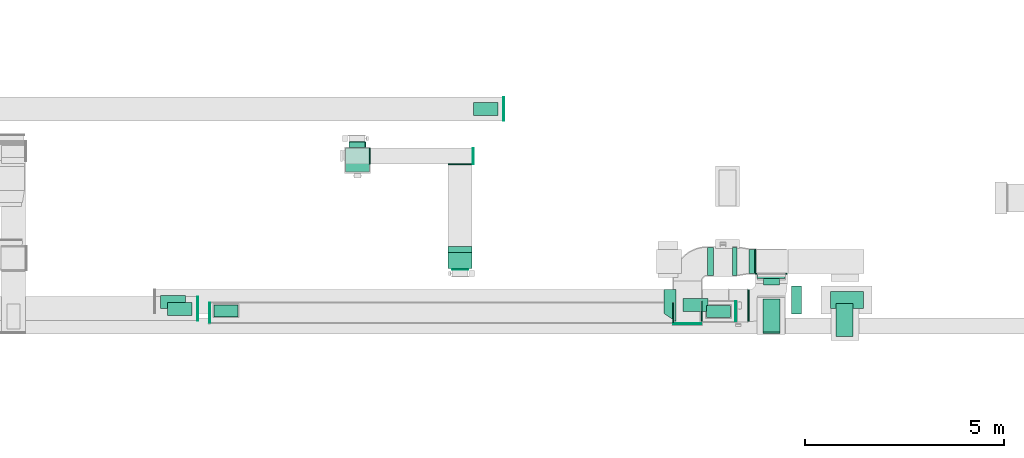
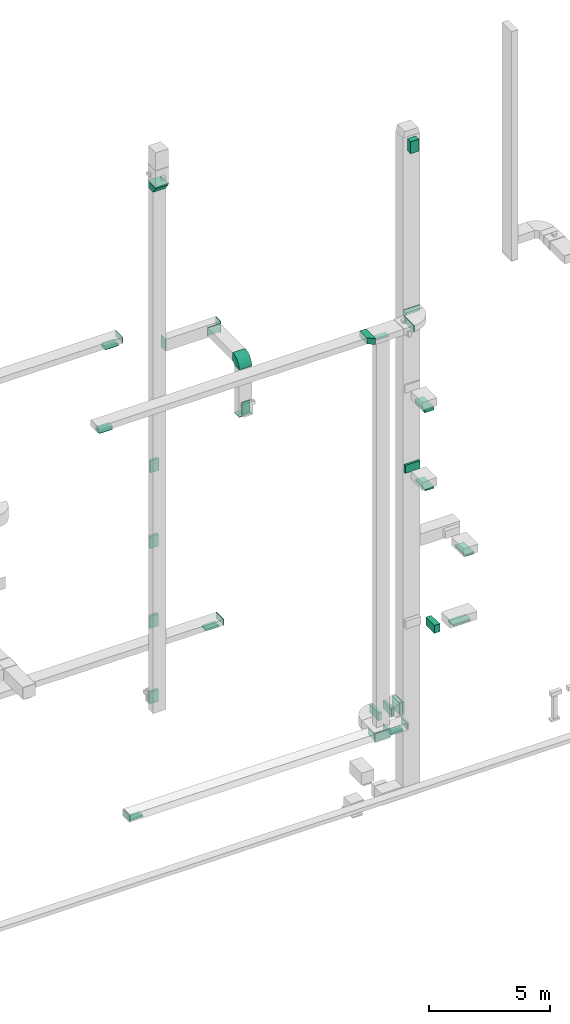
# One storey, part 16 of 29: 25 flow fittings, 22 flow segments, 6 flow terminals.
"""IFC2X3 building model written with IfcOpenShell, lengths in millimetres."""

from ifc_helpers import new_model, entity, si_unit, converted_unit, derived_unit, direction, frame, frame_2d, origin, origin_2d_with_axis, place, context, subcontext, project, spatial, polyline, circle_curve, parameter, trimmed, segment, composite_curve, rectangle, outline, extrude, source, transform, mapped, material, type_object, type_shapes, element, save


model = new_model("IFC2X3")

# Units and contexts
model_context = context("Model", 3, precision=0.01, world=origin(), true_north=direction((6.12303176911189e-17, 1.0)))
body_context = subcontext(model_context, "Body", "Model", "MODEL_VIEW")
ifc_project = project(units=[si_unit("LENGTHUNIT", "METRE", prefix="MILLI"), si_unit("AREAUNIT", "SQUARE_METRE"), si_unit("VOLUMEUNIT", "CUBIC_METRE"), converted_unit("PLANEANGLEUNIT", "DEGREE", entity("IfcRatioMeasure", 0.0174532925199433), si_unit("PLANEANGLEUNIT", "RADIAN"), dimensions=[0, 0, 0, 0, 0, 0, 0]), si_unit("MASSUNIT", "GRAM", prefix="KILO"), derived_unit("MASSDENSITYUNIT", [(si_unit("MASSUNIT", "GRAM", prefix="KILO"), 1), (si_unit("LENGTHUNIT", "METRE"), -3)]), derived_unit("MOMENTOFINERTIAUNIT", [(si_unit("LENGTHUNIT", "METRE"), 4)]), si_unit("TIMEUNIT", "SECOND"), si_unit("FREQUENCYUNIT", "HERTZ"), si_unit("THERMODYNAMICTEMPERATUREUNIT", "DEGREE_CELSIUS"), derived_unit("THERMALTRANSMITTANCEUNIT", [(si_unit("MASSUNIT", "GRAM", prefix="KILO"), 1), (si_unit("THERMODYNAMICTEMPERATUREUNIT", "KELVIN"), -1), (si_unit("TIMEUNIT", "SECOND"), -3)]), derived_unit("VOLUMETRICFLOWRATEUNIT", [(si_unit("LENGTHUNIT", "METRE"), 3), (si_unit("TIMEUNIT", "SECOND"), -1)]), derived_unit("MASSFLOWRATEUNIT", [(si_unit("MASSUNIT", "GRAM", prefix="KILO"), 1), (si_unit("TIMEUNIT", "SECOND"), -1)]), derived_unit("ROTATIONALFREQUENCYUNIT", [(si_unit("TIMEUNIT", "SECOND"), -1)]), si_unit("ELECTRICCURRENTUNIT", "AMPERE"), si_unit("ELECTRICVOLTAGEUNIT", "VOLT"), si_unit("POWERUNIT", "WATT"), si_unit("FORCEUNIT", "NEWTON", prefix="KILO"), si_unit("ILLUMINANCEUNIT", "LUX"), si_unit("LUMINOUSFLUXUNIT", "LUMEN"), si_unit("LUMINOUSINTENSITYUNIT", "CANDELA"), derived_unit("USERDEFINED", [(si_unit("MASSUNIT", "GRAM", prefix="KILO"), -1), (si_unit("LENGTHUNIT", "METRE"), -2), (si_unit("TIMEUNIT", "SECOND"), 3), (si_unit("LUMINOUSFLUXUNIT", "LUMEN"), 1)]), derived_unit("LINEARVELOCITYUNIT", [(si_unit("LENGTHUNIT", "METRE"), 1), (si_unit("TIMEUNIT", "SECOND"), -1)]), si_unit("PRESSUREUNIT", "PASCAL"), derived_unit("USERDEFINED", [(si_unit("LENGTHUNIT", "METRE"), -2), (si_unit("MASSUNIT", "GRAM", prefix="KILO"), 1), (si_unit("TIMEUNIT", "SECOND"), -2)]), derived_unit("LINEARFORCEUNIT", [(si_unit("MASSUNIT", "GRAM", prefix="KILO"), 1), (si_unit("LENGTHUNIT", "METRE"), 1), (si_unit("TIMEUNIT", "SECOND"), -2), (si_unit("LENGTHUNIT", "METRE"), -1)]), derived_unit("PLANARFORCEUNIT", [(si_unit("MASSUNIT", "GRAM", prefix="KILO"), 1), (si_unit("LENGTHUNIT", "METRE"), 1), (si_unit("TIMEUNIT", "SECOND"), -2), (si_unit("LENGTHUNIT", "METRE"), -2)])], contexts=[model_context])

# Site, building, storey
site_placement = place(None, frame((0.0, -0.00077364408347762, 0.0)))
site = spatial("IfcSite", under=ifc_project, at=site_placement, CompositionType="ELEMENT")
building_placement = place(site_placement, origin())
building = spatial("IfcBuilding", under=site, at=building_placement, CompositionType="ELEMENT")
storey_placement = place(building_placement, origin())
storey = spatial("IfcBuildingStorey", under=building, at=storey_placement, CompositionType="ELEMENT", Elevation=0.0)

# Flow segments
duct_segment_type_1 = type_object("IfcDuctSegmentType", PredefinedType="NOTDEFINED")
flow_segment_1_placement = place(storey_placement, frame((62668.848346122, 10217.0329689013, 30600.0)))
element("IfcFlowSegment", 1, at=flow_segment_1_placement, inside=storey, type_object=duct_segment_type_1, context=body_context, shape_type="SweptSolid", body=[
    extrude(rectangle(XDim=271.467042236398, YDim=400.000000000004, at=frame_2d((0.0, 4.33431068813661e-12), x_axis=(1.0, 0.0))), frame((200.0, 135.733521118199, 0.0), z_axis=(0.0, 0.0, 1.0), x_axis=(0.0, 1.0, 0.0)), (0.0, 0.0, 1.0), 600.000000000002),
])
flow_segment_2_placement = place(storey_placement, frame((62659.6308621108, 9000.33800408166, 14399.25)))
element("IfcFlowSegment", 2, at=flow_segment_2_placement, inside=storey, type_object=duct_segment_type_1, context=body_context, shape_type="SweptSolid", body=[
    extrude(rectangle(XDim=425.000000000007, YDim=825.0, at=frame_2d((0.0, -5.40012479177676e-13), x_axis=(1.0, 0.0))), frame((212.500000000004, 412.500000000002, 0.0)), (0.0, 0.0, 1.0), 80.7499999999946),
])
flow_segment_3_placement = place(storey_placement, frame((64497.8098723452, 8920.33800408166, 10500.0)))
element("IfcFlowSegment", 3, at=flow_segment_3_placement, inside=storey, type_object=duct_segment_type_1, context=body_context, shape_type="SweptSolid", body=[
    extrude(rectangle(XDim=825.000000000001, YDim=424.999999999999, at=frame_2d((5.40012479177676e-13, 0.0), x_axis=(1.0, 0.0))), frame((212.500000000004, 412.499999999999, 0.0), z_axis=(0.0, 0.0, 1.0), x_axis=(0.0, 1.0, 0.0)), (0.0, 0.0, 1.0), 79.9999999999818),
])
flow_segment_4_placement = place(storey_placement, frame((62661.6308621108, 9040.33800408165, 18299.5090681927)))
element("IfcFlowSegment", 4, at=flow_segment_4_placement, inside=storey, type_object=duct_segment_type_1, context=body_context, shape_type="SweptSolid", body=[
    extrude(rectangle(XDim=425.000000000007, YDim=825.0, at=frame_2d((8.66862137627322e-12, -5.40012479177676e-13), x_axis=(1.0, 0.0))), frame((212.500000000012, 412.500000000011, 0.0), z_axis=(0.0, 0.0, 1.0), x_axis=(-1.0, 0.0, 0.0)), (0.0, 0.0, 1.0), 180.490931807302),
])
flow_segment_5_placement = place(storey_placement, frame((64355.3625351618, 9625.05544364408, 6600.0)))
element("IfcFlowSegment", 5, at=flow_segment_5_placement, inside=storey, type_object=duct_segment_type_1, context=body_context, shape_type="SweptSolid", body=[
    extrude(rectangle(XDim=425.0, YDim=825.000000000003, at=frame_2d((5.40012479177676e-13, 0.0), x_axis=(1.0, 0.0))), frame((412.500000000002, 212.499999999999, 0.0), z_axis=(0.0, 0.0, 1.0), x_axis=(0.0, -1.0, 0.0)), (0.0, 0.0, 1.0), 79.9999999999991),
])
flow_segment_6_placement = place(storey_placement, frame((62307.0867859532, 10508.5115060304, 2350.0)))
element("IfcFlowSegment", 6, at=flow_segment_6_placement, inside=storey, type_object=duct_segment_type_1, context=body_context, shape_type="SweptSolid", body=[
    extrude(rectangle(XDim=143.50000000008, YDim=600.0, at=frame_2d((0.0, 1.08002495835535e-12), x_axis=(1.0, 0.0))), frame((71.75000000004, 300.0, 0.0), z_axis=(0.0, 0.0, 1.0), x_axis=(-1.0, 0.0, 0.0)), (0.0, 0.0, 1.0), 600.0),
])
flow_segment_7_placement = place(storey_placement, frame((61244.3470649029, 9400.08046605664, 2400.0)))
element("IfcFlowSegment", 7, at=flow_segment_7_placement, inside=storey, type_object=duct_segment_type_1, context=body_context, shape_type="SweptSolid", body=[
    extrude(rectangle(XDim=600.000000000002, YDim=300.0, at=frame_2d((0.0, 5.40012479177676e-13), x_axis=(1.0, 0.0))), frame((300.0, 150.0, 0.0)), (0.0, 0.0, 1.0), 79.999999999987),
])
flow_segment_8_placement = place(storey_placement, frame((48887.0989802705, 9417.33580520122, 2400.0)))
element("IfcFlowSegment", 8, at=flow_segment_8_placement, inside=storey, type_object=duct_segment_type_1, context=body_context, shape_type="SweptSolid", body=[
    extrude(rectangle(XDim=600.000000000002, YDim=300.0, at=frame_2d((0.0, -1.62003743753303e-12), x_axis=(1.0, 0.0))), frame((300.0, 150.0, 0.0)), (0.0, 0.0, 1.0), 79.9999999999769),
])
flow_segment_9_placement = place(storey_placement, frame((47545.3424852345, 9625.44969494267, 22200.0)))
element("IfcFlowSegment", 9, at=flow_segment_9_placement, inside=storey, type_object=duct_segment_type_1, context=body_context, shape_type="SweptSolid", body=[
    extrude(rectangle(XDim=325.0, YDim=624.999999999996, at=origin_2d_with_axis()), frame((312.499999999998, 162.5, 0.0), z_axis=(0.0, 0.0, 1.0), x_axis=(0.0, -1.0, 0.0)), (0.0, 0.0, 1.0), 129.999999999996),
])
flow_segment_10_placement = place(storey_placement, frame((55390.608515848, 14462.3652479956, 6600.0)))
element("IfcFlowSegment", 10, at=flow_segment_10_placement, inside=storey, type_object=duct_segment_type_1, context=body_context, shape_type="SweptSolid", body=[
    extrude(rectangle(XDim=324.999999999998, YDim=624.999999999996, at=origin_2d_with_axis()), frame((312.499999999998, 162.500000000004, 0.0), z_axis=(0.0, 0.0, 1.0), x_axis=(0.0, -1.0, 0.0)), (0.0, 0.0, 1.0), 80.0000000000002),
])
flow_segment_11_placement = place(storey_placement, frame((47714.4764015712, 9445.81794515242, 26450.0)))
element("IfcFlowSegment", 11, at=flow_segment_11_placement, inside=storey, type_object=duct_segment_type_1, context=body_context, shape_type="SweptSolid", body=[
    extrude(rectangle(XDim=624.999999999997, YDim=324.999999999999, at=frame_2d((0.0, 5.40012479177676e-13), x_axis=(1.0, 0.0))), frame((312.499999999998, 162.5, 0.0)), (0.0, 0.0, 1.0), 129.999999999996),
])
flow_segment_12_placement = place(storey_placement, frame((62506.9964758452, 10379.5449845687, 14500.0)))
element("IfcFlowSegment", 12, at=flow_segment_12_placement, inside=storey, type_object=duct_segment_type_1, context=body_context, shape_type="SweptSolid", body=[
    extrude(rectangle(XDim=104.948641174258, YDim=700.0, at=frame_2d((-1.08357767203415e-12, 4.32009983342141e-12), x_axis=(1.0, 0.0))), frame((350.006816465348, 52.5198051981984, 0.0), z_axis=(0.0, 0.0, 1.0), x_axis=(-0.000129957297672545, 0.99999999155555, 0.0)), (0.0, 0.0, 1.0), 400.0),
])
flow_segment_13_placement = place(storey_placement, frame((62279.4294883709, 9298.83392450255, 22350.0)))
element("IfcFlowSegment", 13, at=flow_segment_13_placement, inside=storey, type_object=duct_segment_type_1, context=body_context, shape_type="SweptSolid", body=[
    extrude(rectangle(XDim=40.2898557493053, YDim=800.000000000001, at=frame_2d((4.33253433129721e-12, 0.0), x_axis=(1.0, 0.0))), frame((20.1449278746483, 400.0, 0.0), z_axis=(0.0, 0.0, 1.0), x_axis=(-1.0, 0.0, 0.0)), (0.0, 0.0, 1.0), 300.000000000001),
])
flow_segment_14_placement = place(storey_placement, frame((63370.6816618024, 9485.38587338601, 6700.0)))
element("IfcFlowSegment", 14, at=flow_segment_14_placement, inside=storey, type_object=duct_segment_type_1, context=body_context, shape_type="SweptSolid", body=[
    extrude(rectangle(XDim=259.316891872014, YDim=700.000000000001, at=origin_2d_with_axis()), frame((129.658445936007, 350.0, 0.0), z_axis=(0.0, 0.0, 1.0), x_axis=(-1.0, 0.0, 0.0)), (0.0, 0.0, 1.0), 400.0),
])
flow_segment_15_placement = place(storey_placement, frame((52274.3668817153, 13667.5127880083, 4500.0)))
element("IfcFlowSegment", 15, at=flow_segment_15_placement, inside=storey, type_object=duct_segment_type_1, context=body_context, shape_type="SweptSolid", body=[
    extrude(rectangle(XDim=132.78072790677, YDim=399.999999999996, at=frame_2d((1.08002495835535e-12, 0.0), x_axis=(1.0, 0.0))), frame((200.0, 66.3903639533839, 0.0), z_axis=(0.0, 0.0, 1.0), x_axis=(0.0, 1.0, 0.0)), (0.0, 0.0, 1.0), 600.0),
])
flow_segment_16_placement = place(storey_placement, frame((61897.5004608103, 10458.547103118, 2450.0)))
element("IfcFlowSegment", 16, at=flow_segment_16_placement, inside=storey, type_object=duct_segment_type_1, context=body_context, shape_type="SweptSolid", body=[
    extrude(rectangle(XDim=109.586325142914, YDim=699.999999999999, at=frame_2d((-8.66151594891562e-12, 1.08002495835535e-12), x_axis=(1.0, 0.0))), frame((54.7931625714656, 350.0, 0.0)), (0.0, 0.0, 1.0), 400.0),
])
flow_segment_17_placement = place(storey_placement, frame((61262.4745067731, 10458.5000121001, 2450.0)))
element("IfcFlowSegment", 17, at=flow_segment_17_placement, inside=storey, type_object=duct_segment_type_1, context=body_context, shape_type="SweptSolid", body=[
    extrude(rectangle(XDim=154.999999573748, YDim=700.000000000001, at=origin_2d_with_axis()), frame((77.5259557834042, 350.005746483941, 0.0), z_axis=(0.0, 0.0, 1.0), x_axis=(0.999999997250103, 7.41605989985116e-05, 0.0)), (0.0, 0.0, 1.0), 400.0),
])
flow_segment_18_placement = place(storey_placement, frame((52271.8668817153, 13667.5127880083, 8300.0)))
element("IfcFlowSegment", 18, at=flow_segment_18_placement, inside=storey, type_object=duct_segment_type_1, context=body_context, shape_type="SweptSolid", body=[
    extrude(rectangle(XDim=130.280727906747, YDim=400.000000000004, at=frame_2d((-2.16715534406831e-12, -4.33431068813661e-12), x_axis=(1.0, 0.0))), frame((200.0, 65.1403639533755, 0.0), z_axis=(0.0, 0.0, 1.0), x_axis=(0.0, 1.0, 0.0)), (0.0, 0.0, 1.0), 600.0),
])
flow_segment_19_placement = place(storey_placement, frame((52294.9501530243, 13667.5127880083, 16100.0)))
element("IfcFlowSegment", 19, at=flow_segment_19_placement, inside=storey, type_object=duct_segment_type_1, context=body_context, shape_type="SweptSolid", body=[
    extrude(rectangle(XDim=137.780727906765, YDim=399.999999999996, at=frame_2d((1.08713038571295e-12, 0.0), x_axis=(1.0, 0.0))), frame((200.0, 68.8903639533833, 0.0), z_axis=(0.0, 0.0, 1.0), x_axis=(0.0, -1.0, 0.0)), (0.0, 0.0, 1.0), 600.000000000002),
])
flow_segment_20_placement = place(storey_placement, frame((52284.9665847859, 13667.5127880083, 12300.0)))
element("IfcFlowSegment", 20, at=flow_segment_20_placement, inside=storey, type_object=duct_segment_type_1, context=body_context, shape_type="SweptSolid", body=[
    extrude(rectangle(XDim=145.280727906756, YDim=400.000000000004, at=frame_2d((0.0, 4.33431068813661e-12), x_axis=(1.0, 0.0))), frame((200.0, 72.6403639533782, 0.0), z_axis=(0.0, 0.0, 1.0), x_axis=(0.0, 1.0, 0.0)), (0.0, 0.0, 1.0), 600.000000000002),
])
flow_segment_21_placement = place(storey_placement, frame((52184.9665847859, 13047.5127880084, 30800.0)))
element("IfcFlowSegment", 21, at=flow_segment_21_placement, inside=storey, type_object=duct_segment_type_1, context=body_context, shape_type="SweptSolid", body=[
    extrude(rectangle(XDim=600.000000000002, YDim=600.000000000002, at=frame_2d((-1.08002495835535e-12, 0.0), x_axis=(1.0, 0.0))), frame((300.0, 300.0, 0.0), z_axis=(0.0, 0.0, 1.0), x_axis=(0.0, 1.0, 0.0)), (0.0, 0.0, 1.0), 69.9999999999841),
])

# Flow fittings
ifc_material_1 = material()
duct_fitting_type_1 = type_object("IfcDuctFittingType", PredefinedType="NOTDEFINED", material=ifc_material_1)
shared_shape_1 = source(origin(), body_context, "Body", "SweptSolid", [
    extrude(rectangle(XDim=24.9999999999999, YDim=700.0, at=frame_2d((-2.89546164822241e-13, 5.6843418860808e-14), x_axis=(1.0, 0.0))), frame((12.500000000006, 0.0, -200.0)), (0.0, 0.0, 1.0), 400.0),
])
type_shapes(duct_fitting_type_1, [shared_shape_1])
flow_fitting_1_placement = place(storey_placement, frame((60762.5004629828, 9250.08574557041, 2650.0), z_axis=(0.0, 0.0, 1.0), x_axis=(0.0, -1.0, 0.0)))
element("IfcFlowFitting", 22, at=flow_fitting_1_placement, inside=storey, type_object=duct_fitting_type_1, material=ifc_material_1, context=body_context, shape_type="MappedRepresentation", body=[
    mapped(shared_shape_1, transform((0.0, 0.0, 0.0), scale=1.0)),
])
duct_fitting_type_2 = type_object("IfcDuctFittingType", PredefinedType="NOTDEFINED", material=ifc_material_1)
shared_shape_2 = source(origin(), body_context, "Body", "SweptSolid", [
    extrude(rectangle(XDim=26.0960000000009, YDim=600.0, at=frame_2d((-4.66293670342566e-13, -1.4210854715202e-13), x_axis=(1.0, 0.0))), frame((6.95199999999999, 0.0, -200.0)), (0.0, 0.0, 1.0), 400.0),
])
type_shapes(duct_fitting_type_2, [shared_shape_2])
for number, where, z_axis, x_axis in (
    (23, (52784.966584786, 13449.5127880083, 22600.0), (0.0, -1.0, 0.0), (1.0, 0.0, 0.0)),
    (24, (55060.3009666719, 13249.5127880083, 22600.0), (0.0, 0.0, -1.0), (0.0, -1.0, 0.0)),
    (25, (55059.3009666718, 10627.5127880084, 20300.0), (-1.0, 0.0, 0.0), (0.0, -1.0, 0.0)),
):
    element("IfcFlowFitting", number, at=place(storey_placement, frame(where, z_axis=z_axis, x_axis=x_axis)), inside=storey, type_object=duct_fitting_type_2, material=ifc_material_1, context=body_context, shape_type="MappedRepresentation", body=[
        mapped(shared_shape_2, transform((0.0, 0.0, 0.0), scale=1.0)),
    ])
duct_fitting_type_3 = type_object("IfcDuctFittingType", PredefinedType="NOTDEFINED", material=ifc_material_1)
shared_shape_3 = source(origin(), body_context, "Body", "SweptSolid", [
    extrude(rectangle(XDim=24.9999999999999, YDim=400.0, at=frame_2d((-1.63424829224823e-13, 0.0), x_axis=(1.0, 0.0))), frame((12.5000000000061, 0.0, -300.0)), (0.0, 0.0, 1.0), 600.0),
])
type_shapes(duct_fitting_type_3, [shared_shape_3])
flow_fitting_2_placement = place(storey_placement, frame((55376.2069900845, 13449.5127880083, 22600.0)))
element("IfcFlowFitting", 26, at=flow_fitting_2_placement, inside=storey, type_object=duct_fitting_type_3, material=ifc_material_1, context=body_context, shape_type="MappedRepresentation", body=[
    mapped(shared_shape_3, transform((0.0, 0.0, 0.0), scale=1.0)),
])
duct_fitting_type_4 = type_object("IfcDuctFittingType", PredefinedType="NOTDEFINED", material=ifc_material_1)
shared_shape_4 = source(origin(), body_context, "Body", "SweptSolid", [
    extrude(rectangle(XDim=26.0960000000291, YDim=600.0, at=frame_2d((-4.67181848762266e-13, -1.4210854715202e-13), x_axis=(1.0, 0.0))), frame((6.95199999999891, 0.0, -150.0)), (0.0, 0.0, 1.0), 300.0),
])
type_shapes(duct_fitting_type_4, [shared_shape_4])
flow_fitting_3_placement = place(storey_placement, frame((61544.3470649029, 9550.08046605664, 2500.0), z_axis=(4.54891432388847e-06, 1.0, 0.0), x_axis=(0.0, 0.0, -1.0)))
element("IfcFlowFitting", 27, at=flow_fitting_3_placement, inside=storey, type_object=duct_fitting_type_4, material=ifc_material_1, context=body_context, shape_type="MappedRepresentation", body=[
    mapped(shared_shape_4, transform((0.0, 0.0, 0.0), scale=1.0)),
])
duct_fitting_type_5 = type_object("IfcDuctFittingType", PredefinedType="NOTDEFINED", material=ifc_material_1)
shared_shape_5 = source(origin(), body_context, "Body", "SweptSolid", [
    extrude(rectangle(XDim=24.9999999999999, YDim=600.0, at=frame_2d((-2.46913600676635e-13, 0.0), x_axis=(1.0, 0.0))), frame((12.500000000006, 0.0, -150.0)), (0.0, 0.0, 1.0), 300.0),
])
type_shapes(duct_fitting_type_5, [shared_shape_5])
for number, where in (
    (28, (48459.8749484537, 9619.58124580589, 26750.0)),
    (29, (56145.9000793308, 14630.0652551759, 6850.0)),
):
    element("IfcFlowFitting", number, at=place(storey_placement, frame(where)), inside=storey, type_object=duct_fitting_type_5, material=ifc_material_1, context=body_context, shape_type="MappedRepresentation", body=[
        mapped(shared_shape_5, transform((0.0, 0.0, 0.0), scale=1.0)),
    ])
duct_fitting_type_6 = type_object("IfcDuctFittingType", PredefinedType="NOTDEFINED", material=ifc_material_1)
shared_shape_6 = source(origin(), body_context, "Body", "SweptSolid", [
    extrude(rectangle(XDim=600.0, YDim=26.0960000000493, at=origin_2d_with_axis()), frame((6.95199999999999, 0.0, -150.0), z_axis=(0.0, 0.0, 1.0), x_axis=(0.0, -1.0, 0.0)), (0.0, 0.0, 1.0), 300.0),
])
type_shapes(duct_fitting_type_6, [shared_shape_6])
flow_fitting_4_placement = place(storey_placement, frame((49187.0989802705, 9567.33580520122, 2500.0), z_axis=(4.54891432388847e-06, 1.0, 0.0), x_axis=(0.0, 0.0, -1.0)))
element("IfcFlowFitting", 30, at=flow_fitting_4_placement, inside=storey, type_object=duct_fitting_type_6, material=ifc_material_1, context=body_context, shape_type="MappedRepresentation", body=[
    mapped(shared_shape_6, transform((0.0, 0.0, 0.0), scale=1.0)),
])

# Flow terminals
ifc_material_2 = material()
air_terminal_type_1 = type_object("IfcAirTerminalType", PredefinedType="NOTDEFINED", material=ifc_material_2)
shared_shape_7 = source(origin(), body_context, "Body", "SweptSolid", [
    extrude(rectangle(XDim=4.0, YDim=599.999999999999, at=origin_2d_with_axis()), frame((0.0, -2.0, -150.0), z_axis=(0.0, 0.0, 1.0), x_axis=(0.0, 1.0, 0.0)), (0.0, 0.0, 1.0), 300.000000000005),
])
type_shapes(air_terminal_type_1, [shared_shape_7])
for number, where, z_axis, x_axis in (
    (31, (49187.0989801866, 9567.52328588576, 2400.0), (4.47091937898172e-07, -1.0, 0.0), (1.0, 4.47091937898172e-07, 0.0)),
    (32, (61544.3470649029, 9550.08046605664, 2400.0), (4.54891432388847e-06, 1.0, 0.0), (-1.0, 4.54891432388847e-06, 0.0)),
):
    element("IfcFlowTerminal", number, at=place(storey_placement, frame(where, z_axis=z_axis, x_axis=x_axis)), inside=storey, type_object=air_terminal_type_1, material=ifc_material_2, context=body_context, shape_type="MappedRepresentation", body=[
        mapped(shared_shape_7, transform((0.0, 0.0, 0.0), scale=1.0)),
    ])

# Flow fittings
duct_fitting_type_7 = type_object("IfcDuctFittingType", PredefinedType="NOTDEFINED", material=ifc_material_1)
shared_shape_8 = source(origin(), body_context, "Body", "SweptSolid", [
    extrude(rectangle(XDim=24.9999999999999, YDim=600.0, at=frame_2d((-2.46913600676635e-13, 0.0), x_axis=(1.0, 0.0))), frame((12.500000000006, 0.0, -200.0)), (0.0, 0.0, 1.0), 400.0),
])
type_shapes(duct_fitting_type_7, [shared_shape_8])
flow_fitting_5_placement = place(storey_placement, frame((55060.3009666718, 10827.5127880084, 19900.0), z_axis=(0.0, 1.0, 0.0), x_axis=(0.0, 0.0, -1.0)))
element("IfcFlowFitting", 33, at=flow_fitting_5_placement, inside=storey, type_object=duct_fitting_type_7, material=ifc_material_1, context=body_context, shape_type="MappedRepresentation", body=[
    mapped(shared_shape_8, transform((0.0, 0.0, 0.0), scale=1.0)),
])
duct_fitting_type_8 = type_object("IfcDuctFittingType", PredefinedType="NOTDEFINED", material=ifc_material_1)
shared_shape_9 = source(origin(), body_context, "Body", "SweptSolid", [
    extrude(rectangle(XDim=600.0, YDim=26.0960000000043, at=origin_2d_with_axis()), frame((6.95199999999999, 0.0, -300.0), z_axis=(0.0, 0.0, 1.0), x_axis=(0.0, -1.0, 0.0)), (0.0, 0.0, 1.0), 600.0),
])
type_shapes(duct_fitting_type_8, [shared_shape_9])
flow_fitting_6_placement = place(storey_placement, frame((62470.5867859533, 10808.5115060304, 2650.0), z_axis=(0.0, 1.0, 0.0), x_axis=(-1.0, 0.0, 0.0)))
element("IfcFlowFitting", 34, at=flow_fitting_6_placement, inside=storey, type_object=duct_fitting_type_8, material=ifc_material_1, context=body_context, shape_type="MappedRepresentation", body=[
    mapped(shared_shape_9, transform((0.0, 0.0, 0.0), scale=1.0)),
])
duct_fitting_type_9 = type_object("IfcDuctFittingType", PredefinedType="NOTDEFINED", material=ifc_material_1)
shared_shape_10 = source(origin(), body_context, "Body", "SweptSolid", [
    extrude(rectangle(XDim=26.0960000000156, YDim=300.0, at=frame_2d((-2.32702745961433e-13, -9.9475983006414e-14), x_axis=(1.0, 0.0))), frame((6.95200000000107, 0.0, -400.0)), (0.0, 0.0, 1.0), 800.0),
])
type_shapes(duct_fitting_type_9, [shared_shape_10])
flow_fitting_7_placement = place(storey_placement, frame((62868.6982066293, 10508.5000111377, 22500.0), z_axis=(-1.0, 0.0, 0.0), x_axis=(0.0, -1.0, 0.0)))
element("IfcFlowFitting", 35, at=flow_fitting_7_placement, inside=storey, type_object=duct_fitting_type_9, material=ifc_material_1, context=body_context, shape_type="MappedRepresentation", body=[
    mapped(shared_shape_10, transform((0.0, 0.0, 0.0), scale=1.0)),
])
duct_fitting_type_10 = type_object("IfcDuctFittingType", PredefinedType="NOTDEFINED", material=ifc_material_1)
shared_shape_11 = source(origin(), body_context, "Body", "SweptSolid", [
    extrude(rectangle(XDim=425.0, YDim=26.0960000000087, at=origin_2d_with_axis()), frame((6.95199999999783, 0.0, -412.5), z_axis=(0.0, 0.0, 1.0), x_axis=(0.0, -1.0, 0.0)), (0.0, 0.0, 1.0), 825.0),
])
type_shapes(duct_fitting_type_10, [shared_shape_11])
for number, where, z_axis, x_axis in (
    (36, (64710.3098723452, 9332.83800408166, 10600.0), (0.0, 1.0, 0.0), (0.0, 0.0, -1.0)),
    (37, (64767.8625351618, 9837.55544364408, 6700.0), (1.0, 0.0, 0.0), (0.0, 0.0, -1.0)),
):
    element("IfcFlowFitting", number, at=place(storey_placement, frame(where, z_axis=z_axis, x_axis=x_axis)), inside=storey, type_object=duct_fitting_type_10, material=ifc_material_1, context=body_context, shape_type="MappedRepresentation", body=[
        mapped(shared_shape_11, transform((0.0, 0.0, 0.0), scale=1.0)),
    ])
duct_fitting_type_11 = type_object("IfcDuctFittingType", PredefinedType="NOTDEFINED", material=ifc_material_1)
shared_shape_12 = source(origin(), body_context, "Body", "SweptSolid", [
    extrude(rectangle(XDim=24.9999999999999, YDim=500.0, at=frame_2d((-2.06057393370429e-13, 0.0), x_axis=(1.0, 0.0))), frame((12.5000000000061, 0.0, -150.0)), (0.0, 0.0, 1.0), 300.0),
])
type_shapes(duct_fitting_type_11, [shared_shape_12])
flow_fitting_8_placement = place(storey_placement, frame((61964.2839239349, 9550.08046605666, 2650.0)))
element("IfcFlowFitting", 38, at=flow_fitting_8_placement, inside=storey, type_object=duct_fitting_type_11, material=ifc_material_1, context=body_context, shape_type="MappedRepresentation", body=[
    mapped(shared_shape_12, transform((0.0, 0.0, 0.0), scale=1.0)),
])
flow_fitting_9_placement = place(storey_placement, frame((48788.4461410786, 9517.33562411091, 2650.0), z_axis=(0.0, 0.0, 1.0), x_axis=(-1.0, -4.15635468375343e-07, 0.0)))
element("IfcFlowFitting", 39, at=flow_fitting_9_placement, inside=storey, type_object=duct_fitting_type_11, material=ifc_material_1, context=body_context, shape_type="MappedRepresentation", body=[
    mapped(shared_shape_12, transform((0.0, 0.0, 0.0), scale=1.0)),
])

# Flow terminals
air_terminal_type_2 = type_object("IfcAirTerminalType", PredefinedType="NOTDEFINED", material=ifc_material_2)
shared_shape_13 = source(origin(), body_context, "Body", "SweptSolid", [
    extrude(rectangle(XDim=4.0, YDim=624.999999999999, at=origin_2d_with_axis()), frame((0.0, -2.0, -162.500000000002), z_axis=(0.0, 0.0, 1.0), x_axis=(0.0, 1.0, 0.0)), (0.0, 0.0, 1.0), 325.000000000005),
])
type_shapes(air_terminal_type_2, [shared_shape_13])
for number, where, z_axis, x_axis in (
    (40, (60967.3486253537, 9707.94969494266, 2395.0), (0.0, -1.0, 0.0), (1.0, 0.0, 0.0)),
    (41, (47857.8424852345, 9787.94969494267, 22200.0), (0.0, -1.0, 0.0), (1.0, 0.0, 0.0)),
    (42, (48026.9764015712, 9608.31794515242, 26450.0), (0.0, 1.0, 0.0), (-1.0, 0.0, 0.0)),
    (43, (55703.108515848, 14624.8652479956, 6600.0), (-1.61069216523556e-08, 1.0, 0.0), (-1.0, -1.61069216523556e-08, 0.0)),
):
    element("IfcFlowTerminal", number, at=place(storey_placement, frame(where, z_axis=z_axis, x_axis=x_axis)), inside=storey, type_object=air_terminal_type_2, material=ifc_material_2, context=body_context, shape_type="MappedRepresentation", body=[
        mapped(shared_shape_13, transform((0.0, 0.0, 0.0), scale=1.0)),
    ])

# Flow fittings
duct_fitting_type_12 = type_object("IfcDuctFittingType", PredefinedType="NOTDEFINED", material=ifc_material_1)
shared_shape_14 = source(origin(), body_context, "Body", "SweptSolid", [
    extrude(rectangle(XDim=26.096000000001, YDim=625.0, at=frame_2d((-4.86721773995669e-13, -8.5265128291212e-14), x_axis=(1.0, 0.0))), frame((6.95199999999999, 0.0, -162.5)), (0.0, 0.0, 1.0), 325.0),
])
type_shapes(duct_fitting_type_12, [shared_shape_14])
for number, where, z_axis, x_axis in (
    (44, (47857.8424852345, 9787.94969494268, 22350.0), (0.0, -1.0, 0.0), (0.0, 0.0, -1.0)),
    (45, (60967.3486253537, 9707.94969494266, 22350.0), (0.0, -1.0, 0.0), (0.0, 0.0, -1.0)),
    (46, (48026.9764015712, 9608.31794515246, 26600.0), (0.0, 1.0, 0.0), (0.0, 0.0, -1.0)),
):
    element("IfcFlowFitting", number, at=place(storey_placement, frame(where, z_axis=z_axis, x_axis=x_axis)), inside=storey, type_object=duct_fitting_type_12, material=ifc_material_1, context=body_context, shape_type="MappedRepresentation", body=[
        mapped(shared_shape_14, transform((0.0, 0.0, 0.0), scale=1.0)),
    ])

# Flow segment
duct_segment_type_2 = type_object("IfcDuctSegmentType", PredefinedType="NOTDEFINED")
flow_segment_22_placement = place(storey_placement, frame((54859.3009666718, 10592.5127880084, 20000.0)))
element("IfcFlowSegment", 47, at=flow_segment_22_placement, inside=storey, type_object=duct_segment_type_2, context=body_context, shape_type="SweptSolid", body=[
    extrude(rectangle(XDim=14.9999999999814, YDim=400.000000000004, at=frame_2d((-1.08268949361445e-12, -4.33431068813661e-12), x_axis=(1.0, 0.0))), frame((200.0, 7.49999999998963, 0.0), z_axis=(0.0, 0.0, 1.0), x_axis=(0.0, -1.0, 0.0)), (0.0, 0.0, 1.0), 600.000000000002),
])

# Flow fittings
duct_fitting_type_13 = type_object("IfcDuctFittingType", PredefinedType="NOTDEFINED", material=ifc_material_1)
shared_shape_15 = source(origin(), body_context, "Body", "SweptSolid", [
    extrude(outline(composite_curve([segment(polyline([(-375.0, -175.0), (25.0, -175.0)]), True, "CONTINUOUS"), segment(trimmed(circle_curve(frame_2d((175.0, -175.0), x_axis=(0.0, 1.0)), 150.0), [parameter(0.0)], [parameter(90.0000000000001)], True, "PARAMETER"), False, "CONTINUOUS"), segment(polyline([(175.0, -25.0), (175.0, 375.0)]), True, "CONTINUOUS"), segment(trimmed(circle_curve(frame_2d((175.0, -175.0), x_axis=(0.0, 1.0)), 550.0), [parameter(0.0)], [parameter(90.0)], True, "PARAMETER"), True, "CONTINUOUS")], self_intersect=False)), frame((-175.0, 175.0, -300.0), z_axis=(0.0, 0.0, 1.0), x_axis=(-1.0, 0.0, 0.0)), (0.0, 0.0, 1.0), 600.0),
])
type_shapes(duct_fitting_type_13, [shared_shape_15])
flow_fitting_10_placement = place(storey_placement, frame((55060.3009666719, 10827.5127880084, 22600.0), z_axis=(1.0, 0.0, 0.0), x_axis=(0.0, -1.0, 0.0)))
element("IfcFlowFitting", 48, at=flow_fitting_10_placement, inside=storey, type_object=duct_fitting_type_13, material=ifc_material_1, context=body_context, shape_type="MappedRepresentation", body=[
    mapped(shared_shape_15, transform((0.0, 0.0, 0.0), scale=1.0)),
])
duct_fitting_type_14 = type_object("IfcDuctFittingType", PredefinedType="NOTDEFINED", material=ifc_material_1)
shared_shape_16 = source(origin(), body_context, "Body", "SweptSolid", [
    extrude(rectangle(XDim=625.0, YDim=26.0960000000195, at=frame_2d((-5.6843418860808e-14, 0.0), x_axis=(1.0, 0.0))), frame((6.95199999999999, 0.0, -162.5), z_axis=(0.0, 0.0, 1.0), x_axis=(0.0, -1.0, 0.0)), (0.0, 0.0, 1.0), 325.0),
])
type_shapes(duct_fitting_type_14, [shared_shape_16])
flow_fitting_11_placement = place(storey_placement, frame((55703.108515848, 14624.8652479956, 6700.0), z_axis=(0.0, -1.0, 0.0), x_axis=(0.0, 0.0, -1.0)))
element("IfcFlowFitting", 49, at=flow_fitting_11_placement, inside=storey, type_object=duct_fitting_type_14, material=ifc_material_1, context=body_context, shape_type="MappedRepresentation", body=[
    mapped(shared_shape_16, transform((0.0, 0.0, 0.0), scale=1.0)),
])
duct_fitting_type_15 = type_object("IfcDuctFittingType", PredefinedType="NOTDEFINED", material=ifc_material_1)
shared_shape_17 = source(origin(), body_context, "Body", "SweptSolid", [
    extrude(rectangle(XDim=26.1213371379491, YDim=500.0, at=frame_2d((-3.88133969408955e-13, -1.4210854715202e-13), x_axis=(1.0, 0.0))), frame((6.95199999999999, 0.0, -150.0)), (0.0, 0.0, 1.0), 300.0),
])
type_shapes(duct_fitting_type_15, [shared_shape_17])
flow_fitting_12_placement = place(storey_placement, frame((60412.5004629828, 9517.34090440284, 2650.0), z_axis=(0.0, 0.0, -1.0), x_axis=(-1.0, 0.0, 0.0)))
element("IfcFlowFitting", 50, at=flow_fitting_12_placement, inside=storey, type_object=duct_fitting_type_15, material=ifc_material_1, context=body_context, shape_type="MappedRepresentation", body=[
    mapped(shared_shape_17, transform((0.0, 0.0, 0.0), scale=1.0)),
])
duct_fitting_type_16 = type_object("IfcDuctFittingType", PredefinedType="NOTDEFINED", material=ifc_material_1)
shared_shape_18 = source(origin(), body_context, "Body", "SweptSolid", [
    extrude(rectangle(XDim=500.0, YDim=26.096, at=origin_2d_with_axis()), frame((6.95199999999999, 0.0, -150.0), z_axis=(0.0, 0.0, 1.0), x_axis=(0.0, -1.0, 0.0)), (0.0, 0.0, 1.0), 300.0),
])
type_shapes(duct_fitting_type_16, [shared_shape_18])
flow_fitting_13_placement = place(storey_placement, frame((61112.5004629828, 9550.08046605657, 2650.0), z_axis=(0.0, 0.0, -1.0), x_axis=(1.0, 0.0, 0.0)))
element("IfcFlowFitting", 51, at=flow_fitting_13_placement, inside=storey, type_object=duct_fitting_type_16, material=ifc_material_1, context=body_context, shape_type="MappedRepresentation", body=[
    mapped(shared_shape_18, transform((0.0, 0.0, 0.0), scale=1.0)),
])
duct_fitting_type_17 = type_object("IfcDuctFittingType", PredefinedType="NOTDEFINED", material=ifc_material_1)
shared_shape_19 = source(origin(), body_context, "Body", "SweptSolid", [
    extrude(outline(polyline([(-149.999977344191, -350.0), (150.00002265581, -350.0), (149.999983817279, 250.0), (-150.000029128898, 450.0), (-149.999977344191, -350.0)])), frame((150.0, -50.0000097096916, -150.0)), (0.0, 0.0, 1.0), 300.0),
])
type_shapes(duct_fitting_type_17, [shared_shape_19])
flow_fitting_14_placement = place(storey_placement, frame((60475.3424852345, 9699.95823987354, 22500.0), z_axis=(0.0, 0.0, 1.0), x_axis=(-0.999999805808052, 0.000623204507744245, 0.0)))
element("IfcFlowFitting", 52, at=flow_fitting_14_placement, inside=storey, type_object=duct_fitting_type_17, material=ifc_material_1, context=body_context, shape_type="MappedRepresentation", body=[
    mapped(shared_shape_19, transform((0.0, 0.0, 0.0), scale=1.0)),
])
duct_fitting_type_18 = type_object("IfcDuctFittingType", PredefinedType="NOTDEFINED", material=ifc_material_1)
shared_shape_20 = source(origin(), body_context, "Body", "SweptSolid", [
    extrude(outline(polyline([(-150.0, -250.0), (150.0, -250.0), (150.0, 150.0), (-150.0, 350.0), (-150.0, -250.0)])), frame((150.0, -300.0, 50.0), z_axis=(0.0, 1.0, 0.0), x_axis=(1.0, 0.0, 0.0)), (0.0, 0.0, 1.0), 600.0),
])
type_shapes(duct_fitting_type_18, [shared_shape_20])
flow_fitting_15_placement = place(storey_placement, frame((52484.9665847859, 13347.5127880084, 30800.0), z_axis=(0.0, 1.0, 0.0), x_axis=(0.0, 0.0, -1.0)))
element("IfcFlowFitting", 53, at=flow_fitting_15_placement, inside=storey, type_object=duct_fitting_type_18, material=ifc_material_1, context=body_context, shape_type="MappedRepresentation", body=[
    mapped(shared_shape_20, transform((0.0, 0.0, 0.0), scale=1.0)),
])

save(model, "model.ifc")
